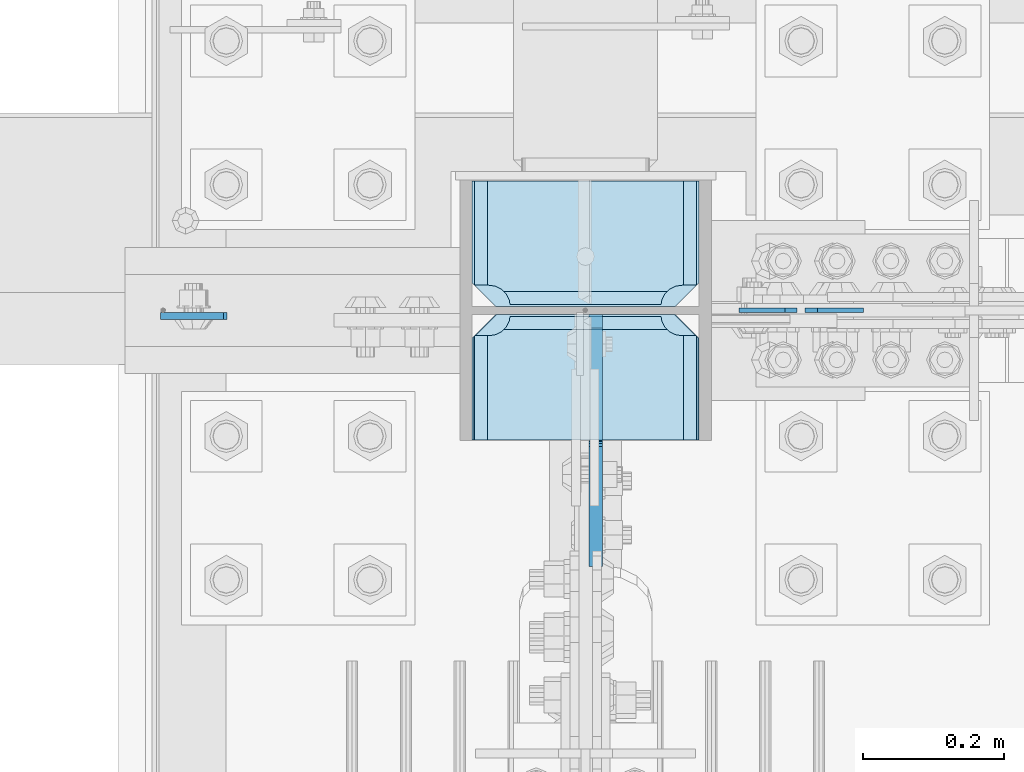
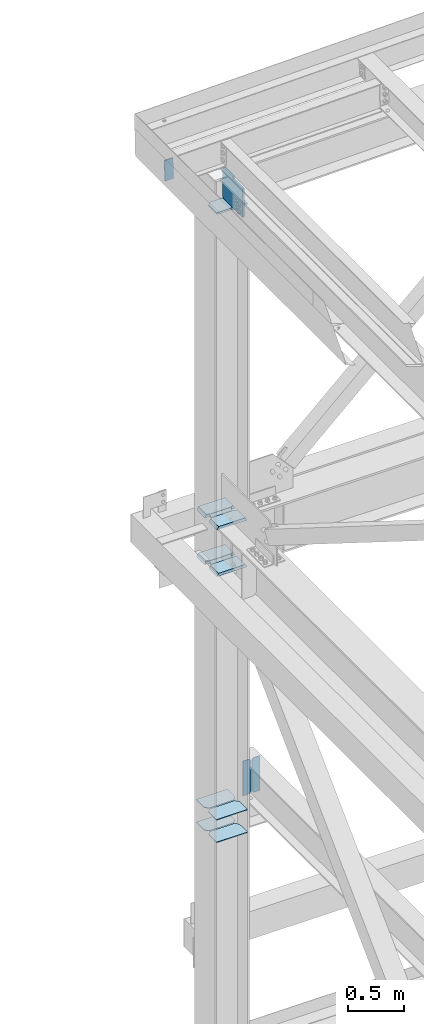
# One storey, part 3538 of 3843: 13 plates, 3 elements without a shape of their own.
"""IFC2X3 building model written with IfcOpenShell, lengths in millimetres."""

import ifcopenshell
import ifcopenshell.guid

model = None  # the IFC model being written
_history = None  # IfcOwnerHistory: only IFC2X3 demands one
_inside = {}  # id of a spatial element -> (the spatial element, [elements in it])
_under = {}  # id of a project, library or spatial element -> (it, [spatial elements below it])
_declared = {}  # id of a project -> (the project, [libraries it declares])
_typed = {}  # id of a type object -> (the type object, [elements of that type])
_made_of = {}  # id of a material, layer set ... -> (it, [elements and type objects made of it])


def new_model(schema):
    """Start an empty IFC model of exactly this schema.

    Asked for "IFC4X3", IfcOpenShell would pick the latest addendum, in which some entities
    have other attributes; the version numbers below select the first issue.
    IFC2X3 requires an IfcOwnerHistory on every rooted entity: one is made here for all.
    """
    global model, _history
    if schema == "IFC4X3":
        model = ifcopenshell.file(schema_version=(4, 3, 0, 0))
    else:
        model = ifcopenshell.file(schema=schema)
    _inside.clear()
    _under.clear()
    _declared.clear()
    _typed.clear()
    _made_of.clear()
    _history = None
    if model.schema == "IFC2X3":
        org = make("IfcOrganization", Name="unknown")
        user = make(
            "IfcPersonAndOrganization",
            ThePerson=make("IfcPerson", FamilyName="unknown"),
            TheOrganization=org,
        )
        app = make(
            "IfcApplication",
            ApplicationDeveloper=org,
            Version="unknown",
            ApplicationFullName="unknown",
            ApplicationIdentifier="unknown",
        )
        _history = make(
            "IfcOwnerHistory",
            OwningUser=user,
            OwningApplication=app,
            ChangeAction="ADDED",
            CreationDate=0,
        )
    return model


def make(cls, **values):
    """One entity of the class cls with the attributes given. An attribute that is None is left unset."""
    return model.create_entity(
        cls, **{name: value for name, value in values.items() if value is not None}
    )


def rooted(cls, **values):
    """An entity with a GlobalId (a new one), such as an element, a storey or a relation."""
    return make(cls, GlobalId=ifcopenshell.guid.new(), OwnerHistory=_history, **values)


def si_unit(unit_type, name, prefix=None):
    """IfcSIUnit, for example si_unit("LENGTHUNIT", "METRE", prefix="MILLI")."""
    return make("IfcSIUnit", UnitType=unit_type, Prefix=prefix, Name=name)


def assignment(units):
    """IfcUnitAssignment: the units of a project."""
    return None if units is None else make("IfcUnitAssignment", Units=units)


def point(xyz):
    """IfcCartesianPoint."""
    return None if xyz is None else make("IfcCartesianPoint", Coordinates=xyz)


def direction(xyz):
    """IfcDirection."""
    return None if xyz is None else make("IfcDirection", DirectionRatios=xyz)


def frame(location, z_axis=None, x_axis=None):
    """IfcAxis2Placement3D, a coordinate frame: its origin and axes. An axis left out is left unset."""
    return make(
        "IfcAxis2Placement3D",
        Location=point(location),
        Axis=direction(z_axis),
        RefDirection=direction(x_axis),
    )


def origin_with_axes():
    """The frame at (0, 0, 0) with the z axis (0, 0, 1) and the x axis (1, 0, 0) written out."""
    return frame((0.0, 0.0, 0.0), z_axis=(0.0, 0.0, 1.0), x_axis=(1.0, 0.0, 0.0))


def place(relative_to, where):
    """IfcLocalPlacement: puts the frame where relative to a parent placement (None: the world)."""
    return make(
        "IfcLocalPlacement", PlacementRelTo=relative_to, RelativePlacement=where
    )


def context(
    kind, dimensions, precision=None, world=None, true_north=None, identifier=None
):
    """IfcGeometricRepresentationContext, for example the 3D "Model" context."""
    return make(
        "IfcGeometricRepresentationContext",
        ContextIdentifier=identifier,
        ContextType=kind,
        CoordinateSpaceDimension=dimensions,
        Precision=precision,
        WorldCoordinateSystem=world,
        TrueNorth=true_north,
    )


def subcontext(parent, identifier, kind, view, scale=None):
    """IfcGeometricRepresentationSubContext, for example "Body" below "Model"."""
    return make(
        "IfcGeometricRepresentationSubContext",
        ContextIdentifier=identifier,
        ContextType=kind,
        ParentContext=parent,
        TargetScale=scale,
        TargetView=view,
    )


def project(units=None, contexts=None):
    """IfcProject with its units and contexts."""
    return rooted(
        "IfcProject",
        Name="project",
        RepresentationContexts=contexts,
        UnitsInContext=assignment(units),
    )


def spatial(cls, under=None, at=None, **own):
    """A site, building, storey or space (cls), placed at a placement, below another one or the project."""
    s = rooted(cls, ObjectPlacement=at, **own)
    if under is not None:
        _under.setdefault(under.id(), (under, []))[1].append(s)
    return s


def faces_of(points, faces, orient=None, outer=None):
    """IfcFace entities. A face is a list of loops; a loop is a list of indices into points, from 0.

    orient and outer hold one flag for each loop. By default every Orientation is true, the
    first loop of a face is its IfcFaceOuterBound and the others are IfcFaceBound.
    """
    made = []
    for i, loops in enumerate(faces):
        bounds = []
        for j, loop in enumerate(loops):
            is_outer = j == 0 if outer is None else outer[i][j]
            bounds.append(
                make(
                    "IfcFaceOuterBound" if is_outer else "IfcFaceBound",
                    Bound=make("IfcPolyLoop", Polygon=[points[k] for k in loop]),
                    Orientation=True if orient is None else orient[i][j],
                )
            )
        made.append(make("IfcFace", Bounds=bounds))
    return made


def faceted_brep(points, faces, orient=None, outer=None, voids=None):
    """IfcFacetedBrep: a solid bounded by flat faces; with voids (closed shells), ...WithVoids."""
    shared = [point(p) for p in points]
    hull = make("IfcClosedShell", CfsFaces=faces_of(shared, faces, orient, outer))
    if voids is None:
        return make("IfcFacetedBrep", Outer=hull)
    return make(
        "IfcFacetedBrepWithVoids",
        Outer=hull,
        Voids=[
            make(cls, CfsFaces=faces_of(shared, fs, o, b)) for cls, fs, o, b in voids
        ],
    )


def shape(context_of_items, identifier, shape_type, items):
    """IfcShapeRepresentation: the items that make up one representation, for example the "Body"."""
    return make(
        "IfcShapeRepresentation",
        ContextOfItems=context_of_items,
        RepresentationIdentifier=identifier,
        RepresentationType=shape_type,
        Items=items,
    )


def material(Name=None, Category=None):
    """IfcMaterial."""
    return make("IfcMaterial", Name=Name, Category=Category)


def made_of(thing, what):
    """Note that an element or type object is made of a material, layer set ...; save() writes the relation."""
    if what is not None:
        _made_of.setdefault(what.id(), (what, []))[1].append(thing)
    return thing


def type_object(cls, material=None, **own):
    """A type object (cls), such as IfcWallType, which elements share."""
    return made_of(rooted(cls, **own), material)


def element(
    cls,
    number,
    at=None,
    inside=None,
    cuts=None,
    type_object=None,
    material=None,
    context=None,
    identifier="Body",
    shape_type=None,
    held_by="IfcProductDefinitionShape",
    body=None,
    shapes=None,
    **own,
):
    """One element of the class cls, such as IfcWall. Its Tag is "e" and its number.

    at: its placement. inside: the storey or other place that contains it. cuts: it is an
    opening in that element (IfcRelVoidsElement). A single representation is given by context,
    identifier, shape_type and body (its items); several are given by shapes. held_by: the class
    of the entity that holds the representations. save() writes the other relations.
    """
    e = rooted(cls, Tag="e%d" % number, ObjectPlacement=at, **own)
    if body is not None:
        shapes = [shape(context, identifier, shape_type, body)]
    if shapes is not None:
        e.Representation = make(held_by, Representations=shapes)
    if inside is not None:
        _inside.setdefault(inside.id(), (inside, []))[1].append(e)
    if cuts is not None:
        rooted(
            "IfcRelVoidsElement", RelatingBuildingElement=cuts, RelatedOpeningElement=e
        )
    if type_object is not None:
        _typed.setdefault(type_object.id(), (type_object, []))[1].append(e)
    return made_of(e, material)


def aggregate(whole, parts):
    """IfcRelAggregates: a whole, such as a stair, and the parts it consists of."""
    return rooted("IfcRelAggregates", RelatingObject=whole, RelatedObjects=parts)


def save(model, path):
    """Write the relations noted so far, then the file.

    IfcRelAggregates (storeys below a building ...), IfcRelContainedInSpatialStructure (elements
    in a storey), IfcRelDefinesByType, IfcRelAssociatesMaterial and IfcRelDeclares: one each for
    every whole, place, type object, material and project.
    """
    for whole, parts in _under.values():
        aggregate(whole, parts)
    for where, things in _inside.values():
        rooted(
            "IfcRelContainedInSpatialStructure",
            RelatedElements=things,
            RelatingStructure=where,
        )
    for kind, things in _typed.values():
        rooted("IfcRelDefinesByType", RelatedObjects=things, RelatingType=kind)
    for what, things in _made_of.values():
        rooted("IfcRelAssociatesMaterial", RelatedObjects=things, RelatingMaterial=what)
    for by, libraries in _declared.values():
        rooted("IfcRelDeclares", RelatingContext=by, RelatedDefinitions=libraries)
    model.write(path)


model = new_model("IFC2X3")

# Units and contexts
model_context = context("Model", 3, precision=1e-05, world=origin_with_axes())
body_context = subcontext(model_context, "Body", "Model", "MODEL_VIEW")
ifc_project = project(units=[si_unit("LENGTHUNIT", "METRE", prefix="MILLI"), si_unit("AREAUNIT", "SQUARE_METRE"), si_unit("VOLUMEUNIT", "CUBIC_METRE"), si_unit("MASSUNIT", "GRAM", prefix="KILO"), si_unit("TIMEUNIT", "SECOND"), si_unit("PLANEANGLEUNIT", "RADIAN"), si_unit("SOLIDANGLEUNIT", "STERADIAN"), si_unit("THERMODYNAMICTEMPERATUREUNIT", "DEGREE_CELSIUS"), si_unit("LUMINOUSINTENSITYUNIT", "LUMEN")], contexts=[model_context])

# Site, building, storey
site_placement = place(None, origin_with_axes())
site = spatial("IfcSite", under=ifc_project, at=site_placement, CompositionType="ELEMENT")
building_placement = place(site_placement, origin_with_axes())
building = spatial("IfcBuilding", under=site, at=building_placement, Name="Undefined", CompositionType="ELEMENT")
storey_placement = place(building_placement, origin_with_axes())
storey = spatial("IfcBuildingStorey", under=building, at=storey_placement, Name="Undefined", CompositionType="ELEMENT", Elevation=0.0)

# Assembly, plate
assembly_1_placement = place(storey_placement, origin_with_axes())
assembly_1 = element("IfcElementAssembly", 1, at=assembly_1_placement, inside=storey, Name="CHANNEL", AssemblyPlace="NOTDEFINED", PredefinedType="RIGID_FRAME")
ifc_material = material(Name="STEEL/A572-50")
plate_type_1 = type_object("IfcPlateType", PredefinedType="NOTDEFINED")
plate_1_placement = place(assembly_1_placement, frame((76411.941619043, 104551.1625, 46534.2884082036), z_axis=(0.999776270257024, 0.0, 0.0211520550054619), x_axis=(0.0211520550054438, 0.0, -0.999776270257025)))
plate_1 = element("IfcPlate", 2, at=plate_1_placement, type_object=plate_type_1, material=ifc_material, Name="PLATE", context=body_context, shape_type="Brep", body=[
    faceted_brep([(0.0, -4.76249999999709, 0.0), (0.0, -4.76249999999709, 88.9000015258789), (0.0, 4.76249999999709, 88.9000015258789), (0.0, 4.76249999999709, 0.0), (228.600006102781, -4.7625000004191, 88.9000015257589), (228.600006102781, 4.76249999954598, 88.9000015257443), (228.600006103079, -4.7625000004482, 7.27595761418343e-12), (228.600006103079, 4.76249999954598, -7.27595761418343e-12)], [[[0, 1, 2, 3]], [[1, 4, 5, 2]], [[4, 6, 7, 5]], [[6, 0, 3, 7]], [[5, 7, 3, 2]], [[6, 4, 1, 0]]]),
])
aggregate(assembly_1, [plate_1])

# Assembly, plates
assembly_2_placement = place(storey_placement, origin_with_axes())
assembly_2 = element("IfcElementAssembly", 3, at=assembly_2_placement, inside=storey, Name="COLUMN", AssemblyPlace="NOTDEFINED", PredefinedType="RIGID_FRAME")
plate_type_2 = type_object("IfcPlateType", PredefinedType="NOTDEFINED")
plate_2_placement = place(assembly_2_placement, frame((76852.4625, 104564.65625, 41941.75), z_axis=(1.0, 0.0, 0.0), x_axis=(0.0, 1.0, 0.0)))
plate_2 = element("IfcPlate", 4, at=plate_2_placement, type_object=plate_type_2, material=ifc_material, Name="PLATE", context=body_context, shape_type="Brep", body=[
    faceted_brep([(17.7290728964872, 9.33415681798942, 272.460514298873), (21.5053709990898, 15.875, 276.236824608495), (21.5053709990898, 15.875, 44.4381753915077), (17.7290728964872, 9.33415681798942, 48.2144734940957), (9.3207252107095, -5.22975793085789, 52.4987406282016), (3.174499952318, -15.875, 53.472207075858), (3.174499952318, -15.875, 267.202792924145), (9.3207252107095, -5.22975793086516, 268.176247164767), (30.1625003814697, 15.875, 299.168629000924), (30.1625003814697, -15.875, 317.499500047692), (177.799999999999, -15.875, 317.499500047692), (177.799999999999, 15.875, 299.168629000924), (177.799999999999, 15.875, 21.5053709990898), (177.799999999999, -15.875, 3.17449995232164), (30.1625003814697, -15.875, 3.17449995232164), (30.1625003814697, 15.875, 21.5053709990898), (9.32072521071314, -15.875, 268.176259371801), (17.7290728964945, -15.875, 272.460526505907), (24.401975401448, -15.875, 279.133429010864), (24.401975401448, 15.875, 279.133429010864), (28.6862425355503, -15.875, 287.541776696642), (28.6862425355503, 15.875, 287.541776696642), (30.1625003814697, -15.875, 296.862501907352), (30.1625003814697, 15.875, 296.862501907352), (30.1625003814697, -15.875, 23.8124980926514), (30.1625003814697, 15.875, 23.8124980926514), (28.6862425355503, -15.875, 33.1332233033609), (28.6862425355503, 15.875, 33.1332233033609), (24.401975401448, -15.875, 41.5415709891386), (24.401975401448, 15.875, 41.5415709891386), (17.7290728964945, -15.875, 48.2144734940957), (9.32072521071677, -15.875, 52.4987406282016)], [[[0, 1, 2, 3, 4, 5, 6, 7]], [[8, 9, 10, 11]], [[12, 13, 14, 15]], [[16, 7, 6]], [[16, 17, 0, 7]], [[17, 18, 19, 1, 0]], [[18, 20, 21, 19]], [[20, 22, 23, 21]], [[23, 22, 9, 8]], [[13, 12, 11, 10]], [[24, 25, 15, 14]], [[24, 26, 27, 25]], [[26, 28, 29, 27]], [[29, 28, 30, 3, 2]], [[30, 31, 4, 3]], [[31, 5, 4]], [[19, 21, 23, 8, 11, 12, 15, 25, 27, 29, 2, 1]], [[31, 30, 28, 26, 24, 14, 13, 10, 9, 22, 20, 18, 17, 16, 6, 5]]]),
])
plate_3_placement = place(assembly_2_placement, frame((76852.4625, 104564.65625, 42452.925), z_axis=(1.0, 0.0, 0.0), x_axis=(0.0, 1.0, 0.0)))
plate_3 = element("IfcPlate", 5, at=plate_3_placement, type_object=plate_type_2, material=ifc_material, Name="PLATE", context=body_context, shape_type="Brep", body=[
    faceted_brep([(17.7290728964945, 9.33436282556067, 272.460526505907), (21.5053709990898, 15.875, 276.236824608495), (21.5053709990898, 15.875, 44.4381753915077), (17.7290728964945, 9.33436282556067, 48.2144734940957), (9.32072521071677, -5.22909322453052, 52.4987406282016), (3.174499952318, -15.875, 53.472207075858), (3.174499952318, -15.875, 267.202792924145), (9.32072521071314, -5.22909322453052, 268.176259371801), (30.1625003814697, 15.875, 299.168629000924), (30.1625003814697, -15.875, 317.499500047692), (177.799999999999, -15.875, 317.499500047692), (177.799999999999, 15.875, 299.168629000924), (177.799999999999, 15.875, 21.5053709990898), (177.799999999999, -15.875, 3.17449995232164), (30.1625003814697, -15.875, 3.17449995232164), (30.1625003814697, 15.875, 21.5053709990898), (9.32072521071314, -15.875, 268.176259371801), (17.7290728964945, -15.875, 272.460526505907), (24.401975401448, -15.875, 279.133429010864), (24.401975401448, 15.875, 279.133429010864), (28.6862425355503, -15.875, 287.541776696642), (28.6862425355503, 15.875, 287.541776696642), (30.1625003814697, -15.875, 296.862501907352), (30.1625003814697, 15.875, 296.862501907352), (30.1625003814697, -15.875, 23.8124980926514), (30.1625003814697, 15.875, 23.8124980926514), (28.6862425355503, -15.875, 33.1332233033609), (28.6862425355503, 15.875, 33.1332233033609), (24.401975401448, -15.875, 41.5415709891386), (24.401975401448, 15.875, 41.5415709891386), (17.7290728964945, -15.875, 48.2144734940957), (9.32072521071677, -15.875, 52.4987406282016)], [[[0, 1, 2, 3, 4, 5, 6, 7]], [[8, 9, 10, 11]], [[12, 13, 14, 15]], [[16, 7, 6]], [[16, 17, 0, 7]], [[17, 18, 19, 1, 0]], [[18, 20, 21, 19]], [[20, 22, 23, 21]], [[23, 22, 9, 8]], [[13, 12, 11, 10]], [[24, 25, 15, 14]], [[24, 26, 27, 25]], [[26, 28, 29, 27]], [[29, 28, 30, 3, 2]], [[30, 31, 4, 3]], [[31, 5, 4]], [[19, 21, 23, 8, 11, 12, 15, 25, 27, 29, 2, 1]], [[31, 30, 28, 26, 24, 14, 13, 10, 9, 22, 20, 18, 17, 16, 6, 5]]]),
])
plate_4_placement = place(assembly_2_placement, frame((76852.4625, 104375.74375, 41941.75), z_axis=(1.0, 0.0, 0.0), x_axis=(0.0, 1.0, 0.0)))
plate_4 = element("IfcPlate", 6, at=plate_4_placement, type_object=plate_type_2, material=ifc_material, Name="PLATE", context=body_context, shape_type="Brep", body=[
    faceted_brep([(160.070927103505, 9.33329077896633, 48.2144734940957), (156.294129000915, 15.875, 44.437675391513), (156.294129000915, 15.875, 276.23732460849), (160.070927103505, 9.33329077896633, 272.460526505907), (168.479274789282, -5.23062396988826, 268.176259371801), (174.625000047687, -15.875, 267.202872116366), (174.625000047687, -15.875, 53.4721278836369), (168.479274789282, -5.23062396988826, 52.4987406282016), (147.63749961853, 15.875, 21.5053709990898), (147.63749961853, -15.875, 3.17449995232164), (0.0, -15.875, 3.17449995232164), (0.0, 15.875, 21.5053709990898), (0.0, 15.875, 299.168629000924), (0.0, -15.875, 317.499500047692), (147.63749961853, -15.875, 317.499500047692), (147.63749961853, 15.875, 299.168629000924), (147.63749961853, -15.875, 296.862501907352), (147.63749961853, 15.875, 296.862501907352), (149.113757464445, -15.875, 287.541776696642), (149.113757464445, 15.875, 287.541776696642), (153.398024598548, -15.875, 279.133429010864), (153.398024598548, 15.875, 279.133429010864), (160.070927103505, -15.875, 272.460526505907), (168.479274789282, -15.875, 268.176259371801), (168.479274789282, -15.875, 52.4987406282016), (160.070927103505, -15.875, 48.2144734940957), (153.398024598548, -15.875, 41.5415709891386), (153.398024598548, 15.875, 41.5415709891386), (149.113757464449, -15.875, 33.1332233033609), (149.113757464449, 15.875, 33.1332233033609), (147.63749961853, -15.875, 23.8124980926514), (147.63749961853, 15.875, 23.8124980926514)], [[[0, 1, 2, 3, 4, 5, 6, 7]], [[8, 9, 10, 11]], [[12, 13, 14, 15]], [[13, 12, 11, 10]], [[16, 17, 15, 14]], [[16, 18, 19, 17]], [[18, 20, 21, 19]], [[21, 20, 22, 3, 2]], [[22, 23, 4, 3]], [[23, 5, 4]], [[24, 7, 6]], [[24, 25, 0, 7]], [[25, 26, 27, 1, 0]], [[26, 28, 29, 27]], [[28, 30, 31, 29]], [[31, 30, 9, 8]], [[27, 29, 31, 8, 11, 12, 15, 17, 19, 21, 2, 1]], [[9, 30, 28, 26, 25, 24, 6, 5, 23, 22, 20, 18, 16, 14, 13, 10]]]),
])
plate_5_placement = place(assembly_2_placement, frame((76852.4625, 104375.74375, 42452.925), z_axis=(1.0, 0.0, 0.0), x_axis=(0.0, 1.0, 0.0)))
plate_5 = element("IfcPlate", 7, at=plate_5_placement, type_object=plate_type_2, material=ifc_material, Name="PLATE", context=body_context, shape_type="Brep", body=[
    faceted_brep([(160.070927103505, 9.33349681380787, 48.2144734940957), (156.294129000915, 15.875, 44.437675391513), (156.294129000915, 15.875, 276.23732460849), (160.070927103505, 9.33349681380787, 272.460526505907), (168.479274789282, -5.2299592362906, 268.176259371801), (174.625000047687, -15.875, 267.202872116366), (174.625000047687, -15.875, 53.4721278836369), (168.479274789282, -5.2299592362906, 52.4987406282016), (147.63749961853, 15.875, 21.5053709990898), (147.63749961853, -15.875, 3.17449995232164), (0.0, -15.875, 3.17449995232164), (0.0, 15.875, 21.5053709990898), (0.0, 15.875, 299.168629000924), (0.0, -15.875, 317.499500047692), (147.63749961853, -15.875, 317.499500047692), (147.63749961853, 15.875, 299.168629000924), (147.63749961853, -15.875, 296.862501907352), (147.63749961853, 15.875, 296.862501907352), (149.113757464445, -15.875, 287.541776696642), (149.113757464445, 15.875, 287.541776696642), (153.398024598548, -15.875, 279.133429010864), (153.398024598548, 15.875, 279.133429010864), (160.070927103505, -15.875, 272.460526505907), (168.479274789282, -15.875, 268.176259371801), (168.479274789282, -15.875, 52.4987406282016), (160.070927103505, -15.875, 48.2144734940957), (153.398024598548, -15.875, 41.5415709891386), (153.398024598548, 15.875, 41.5415709891386), (149.113757464449, -15.875, 33.1332233033609), (149.113757464449, 15.875, 33.1332233033609), (147.63749961853, -15.875, 23.8124980926514), (147.63749961853, 15.875, 23.8124980926514)], [[[0, 1, 2, 3, 4, 5, 6, 7]], [[8, 9, 10, 11]], [[12, 13, 14, 15]], [[13, 12, 11, 10]], [[16, 17, 15, 14]], [[16, 18, 19, 17]], [[18, 20, 21, 19]], [[21, 20, 22, 3, 2]], [[22, 23, 4, 3]], [[23, 5, 4]], [[24, 7, 6]], [[24, 25, 0, 7]], [[25, 26, 27, 1, 0]], [[26, 28, 29, 27]], [[28, 30, 31, 29]], [[31, 30, 9, 8]], [[27, 29, 31, 8, 11, 12, 15, 17, 19, 21, 2, 1]], [[9, 30, 28, 26, 25, 24, 6, 5, 23, 22, 20, 18, 16, 14, 13, 10]]]),
])
plate_type_3 = type_object("IfcPlateType", PredefinedType="NOTDEFINED")
plate_6_placement = place(assembly_2_placement, frame((76854.05, 104375.74375, 45902.4145639774), z_axis=(1.0, 0.0, 0.0), x_axis=(0.0, 1.0, 0.0)))
plate_6 = element("IfcPlate", 8, at=plate_6_placement, type_object=plate_type_3, material=ifc_material, Name="PLATE", context=body_context, shape_type="Brep", body=[
    faceted_brep([(0.0, -9.52500000000146, 0.0), (0.0, -9.52500000000146, 317.5), (0.0, 9.52500000000146, 317.5), (0.0, 9.52500000000146, 0.0), (144.462501525879, -9.52500000000146, 317.5), (144.462501525879, 9.52500000000146, 317.5), (177.800003051758, -9.52500000000146, 284.162498474121), (177.800003051758, 9.52500000000146, 284.162498474121), (177.800003051758, -9.52500000000146, 33.3375015258789), (177.800003051758, 9.52500000000146, 33.3375015258789), (144.462501525879, -9.52500000000146, 0.0), (144.462501525879, 9.52500000000146, 0.0)], [[[0, 1, 2, 3]], [[1, 4, 5, 2]], [[4, 6, 7, 5]], [[6, 8, 9, 7]], [[8, 10, 11, 9]], [[10, 0, 3, 11]], [[5, 7, 9, 11, 3, 2]], [[10, 8, 6, 4, 1, 0]]]),
])

assembly_3_placement = place(storey_placement, origin_with_axes())
assembly_3 = element("IfcElementAssembly", 9, at=assembly_3_placement, inside=storey, Name="BEAM", AssemblyPlace="NOTDEFINED", PredefinedType="RIGID_FRAME")
plate_type_4 = type_object("IfcPlateType", PredefinedType="NOTDEFINED")
plate_7_placement = place(assembly_3_placement, frame((77405.70625, 104559.1, 39285.8625), z_axis=(0.0, 0.0, 1.0), x_axis=(-1.0, 0.0, 0.0)))
plate_7 = element("IfcPlate", 10, at=plate_7_placement, type_object=plate_type_4, material=ifc_material, Name="PLATE", context=body_context, shape_type="Brep", body=[
    faceted_brep([(0.0, -3.17499999999927, 0.0), (0.0, -3.17500000000291, 381.0), (0.0, 3.17500000000291, 381.0), (0.0, 3.17499999999927, 0.0), (65.0875034332275, -3.17500000000291, 381.0), (65.0875034332275, 3.17500000000291, 381.0), (82.5500030517578, -3.17500000000291, 363.53750038147), (82.5500030517578, 3.17500000000291, 363.53750038147), (82.5500030517578, -3.17500000000291, 17.4624996185303), (82.5500030517578, 3.17500000000291, 17.4624996185303), (65.0875034332275, -3.17500000000291, 0.0), (65.0875034332275, 3.17500000000291, 0.0)], [[[0, 1, 2, 3]], [[1, 4, 5, 2]], [[4, 6, 7, 5]], [[6, 8, 9, 7]], [[8, 10, 11, 9]], [[10, 0, 3, 11]], [[5, 7, 9, 11, 3, 2]], [[10, 8, 6, 4, 1, 0]]]),
])
plate_8_placement = place(assembly_3_placement, frame((77312.04375, 104559.1, 39285.8625), z_axis=(0.0, 0.0, 1.0), x_axis=(-1.0, 0.0, 0.0)))
plate_8 = element("IfcPlate", 11, at=plate_8_placement, type_object=plate_type_4, material=ifc_material, Name="PLATE", context=body_context, shape_type="Brep", body=[
    faceted_brep([(5.82076609134674e-11, -3.17499999999927, 17.4624996185667), (0.0, -3.17500000000291, 363.53750038147), (0.0, 3.17500000000291, 363.53750038147), (0.0, 3.17500000000655, 17.4624996185521), (17.4624996185303, -3.17500000000291, 381.0), (17.4624996185303, 3.17500000000291, 381.0), (82.5500030517578, -3.17500000000291, 381.0), (82.5500030517578, 3.17500000000291, 381.0), (82.5500007629398, -3.17500000000291, 0.0), (82.5500007629398, 3.17500000000291, 0.0), (17.4624996184866, -3.17500000000291, 7.27595761418343e-12), (17.462499618443, 3.17500000000291, -7.27595761418343e-12)], [[[0, 1, 2, 3]], [[1, 4, 5, 2]], [[4, 6, 7, 5]], [[6, 8, 9, 7]], [[8, 10, 11, 9]], [[10, 0, 3, 11]], [[5, 7, 9, 11, 3, 2]], [[10, 8, 6, 4, 1, 0]]]),
])
aggregate(assembly_3, [plate_7, plate_8])

# Plate
plate_type_5 = type_object("IfcPlateType", PredefinedType="NOTDEFINED")
plate_9_placement = place(assembly_2_placement, frame((77173.1375, 104375.74375, 39265.225), z_axis=(-1.0, 0.0, 0.0), x_axis=(0.0, 1.0, 0.0)))
plate_9 = element("IfcPlate", 12, at=plate_9_placement, type_object=plate_type_5, material=ifc_material, Name="PLATE", context=body_context, shape_type="Brep", body=[
    faceted_brep([(0.0, -3.17499999999927, 0.0), (0.0, -3.17500000000291, 320.674987792969), (0.0, 3.17500000000291, 320.674987792969), (0.0, 3.17499999999927, 0.0), (144.462501525879, -3.17500000000291, 320.674987792969), (144.462501525879, 3.17500000000291, 320.674987792969), (177.800003051758, -3.17500000000291, 287.33748626709), (177.800003051758, 3.17500000000291, 287.33748626709), (177.800003051758, -3.17500000000291, 33.3375015258789), (177.800003051758, 3.17500000000291, 33.3375015258789), (144.462501525879, -3.17500000000291, 0.0), (144.462501525879, 3.17500000000291, 0.0)], [[[0, 1, 2, 3]], [[1, 4, 5, 2]], [[4, 6, 7, 5]], [[6, 8, 9, 7]], [[8, 10, 11, 9]], [[10, 0, 3, 11]], [[5, 7, 9, 11, 3, 2]], [[10, 8, 6, 4, 1, 0]]]),
])

plate_10_placement = place(assembly_2_placement, frame((77173.1375, 104564.65625, 39265.225), z_axis=(-1.0, 0.0, 0.0), x_axis=(0.0, 1.0, 0.0)))
plate_10 = element("IfcPlate", 13, at=plate_10_placement, type_object=plate_type_5, material=ifc_material, Name="PLATE", context=body_context, shape_type="Brep", body=[
    faceted_brep([(0.0, -3.17500000000291, 33.3375015258789), (0.0, -3.17500000000291, 287.33748626709), (0.0, 3.17500000000291, 287.33748626709), (0.0, 3.17500000000291, 33.3375015258789), (33.3375015258789, -3.17500000000291, 320.674987792969), (33.3375015258789, 3.17500000000291, 320.674987792969), (177.800003051758, -3.17500000000291, 320.674987792969), (177.800003051758, 3.17500000000291, 320.674987792969), (177.800003051758, -3.17500000000291, 0.0), (177.800003051758, 3.17500000000291, 0.0), (33.3375015258789, -3.17500000000291, 0.0), (33.3375015258789, 3.17500000000291, 0.0)], [[[0, 1, 2, 3]], [[1, 4, 5, 2]], [[4, 6, 7, 5]], [[6, 8, 9, 7]], [[8, 10, 11, 9]], [[10, 0, 3, 11]], [[5, 7, 9, 11, 3, 2]], [[10, 8, 6, 4, 1, 0]]]),
])

plate_11_placement = place(assembly_2_placement, frame((77173.1375, 104375.74375, 39017.575), z_axis=(-1.0, 0.0, 0.0), x_axis=(0.0, 1.0, 0.0)))
plate_11 = element("IfcPlate", 14, at=plate_11_placement, type_object=plate_type_5, material=ifc_material, Name="PLATE", context=body_context, shape_type="Brep", body=[
    faceted_brep([(0.0, -3.17499999999927, 0.0), (0.0, -3.17500000000291, 320.674987792969), (0.0, 3.17500000000291, 320.674987792969), (0.0, 3.17499999999927, 0.0), (144.462501525879, -3.17500000000291, 320.674987792969), (144.462501525879, 3.17500000000291, 320.674987792969), (177.800003051758, -3.17500000000291, 287.33748626709), (177.800003051758, 3.17500000000291, 287.33748626709), (177.800003051758, -3.17500000000291, 33.3375015258789), (177.800003051758, 3.17500000000291, 33.3375015258789), (144.462501525879, -3.17500000000291, 0.0), (144.462501525879, 3.17500000000291, 0.0)], [[[0, 1, 2, 3]], [[1, 4, 5, 2]], [[4, 6, 7, 5]], [[6, 8, 9, 7]], [[8, 10, 11, 9]], [[10, 0, 3, 11]], [[5, 7, 9, 11, 3, 2]], [[10, 8, 6, 4, 1, 0]]]),
])

plate_12_placement = place(assembly_2_placement, frame((77173.1375, 104564.65625, 39017.575), z_axis=(-1.0, 0.0, 0.0), x_axis=(0.0, 1.0, 0.0)))
plate_12 = element("IfcPlate", 15, at=plate_12_placement, type_object=plate_type_5, material=ifc_material, Name="PLATE", context=body_context, shape_type="Brep", body=[
    faceted_brep([(0.0, -3.17500000000291, 33.3375015258789), (0.0, -3.17500000000291, 287.33748626709), (0.0, 3.17500000000291, 287.33748626709), (0.0, 3.17500000000291, 33.3375015258789), (33.3375015258789, -3.17500000000291, 320.674987792969), (33.3375015258789, 3.17500000000291, 320.674987792969), (177.800003051758, -3.17500000000291, 320.674987792969), (177.800003051758, 3.17500000000291, 320.674987792969), (177.800003051758, -3.17500000000291, 0.0), (177.800003051758, 3.17500000000291, 0.0), (33.3375015258789, -3.17500000000291, 0.0), (33.3375015258789, 3.17500000000291, 0.0)], [[[0, 1, 2, 3]], [[1, 4, 5, 2]], [[4, 6, 7, 5]], [[6, 8, 9, 7]], [[8, 10, 11, 9]], [[10, 0, 3, 11]], [[5, 7, 9, 11, 3, 2]], [[10, 8, 6, 4, 1, 0]]]),
])

plate_type_6 = type_object("IfcPlateType", PredefinedType="NOTDEFINED")
plate_13_placement = place(assembly_2_placement, frame((77027.0875003815, 104553.54375, 45930.9895639774), z_axis=(0.0, -0.707106781186682, 0.707106781186413), x_axis=(0.0, -0.707106781186548, -0.707106781186548)))
plate_13 = element("IfcPlate", 16, at=plate_13_placement, type_object=plate_type_6, material=ifc_material, Name="PLATE", context=body_context, shape_type="Brep", body=[
    faceted_brep([(0.0, -9.52500000000146, 0.0), (-214.403614889528, -9.52499999999418, 214.403614889488), (-214.403614889528, 9.52499999999418, 214.403614889488), (0.0, 9.52500000000146, 0.0), (-214.403614889336, -9.52499999999418, 241.344383252748), (-214.403614889336, 9.52499999999418, 241.344383252748), (-101.589147367522, -9.52499999999418, 354.158850774584), (-101.589147367522, 9.52499999999418, 354.158850774584), (-93.731422658424, -9.52499999999418, 346.301126065489), (-93.731422658424, 9.52499999999418, 346.301126065489), (-89.6112461902703, -9.52499999999418, 343.548112165008), (-89.6112461902703, 9.52499999999418, 343.548112165008), (-84.7511666722385, -9.52499999999418, 342.581382242439), (-84.7511666722385, 9.52499999999418, 342.581382242439), (-79.8910871541921, -9.52499999999418, 343.548112165023), (-79.8910871541921, 9.52499999999418, 343.548112165023), (-75.770910686042, -9.52499999999418, 346.301126065511), (-75.770910686042, 9.52499999999418, 346.301126065511), (40.9724185538689, -9.52500000000146, 463.044456243078), (40.9724185538689, 9.52500000000146, 463.044456243078), (265.478821579974, -9.52500000000146, 238.538053217882), (265.478821579974, 9.52500000000146, 238.538053217882), (26.9407683632344, -9.52499999999964, 2.03726813197136e-10), (26.9407683632344, 9.52499999999964, 2.03726813197136e-10)], [[[0, 1, 2, 3]], [[1, 4, 5, 2]], [[4, 6, 7, 5]], [[6, 8, 9, 7]], [[8, 10, 11, 9]], [[10, 12, 13, 11]], [[12, 14, 15, 13]], [[14, 16, 17, 15]], [[16, 18, 19, 17]], [[18, 20, 21, 19]], [[20, 22, 23, 21]], [[22, 0, 3, 23]], [[5, 7, 9, 11, 13, 15, 17, 19, 21, 23, 3, 2]], [[22, 20, 18, 16, 14, 12, 10, 8, 6, 4, 1, 0]]]),
])

aggregate(assembly_2, [plate_9, plate_10, plate_11, plate_12, plate_2, plate_3, plate_4, plate_5, plate_6, plate_13])

save(model, "model.ifc")
